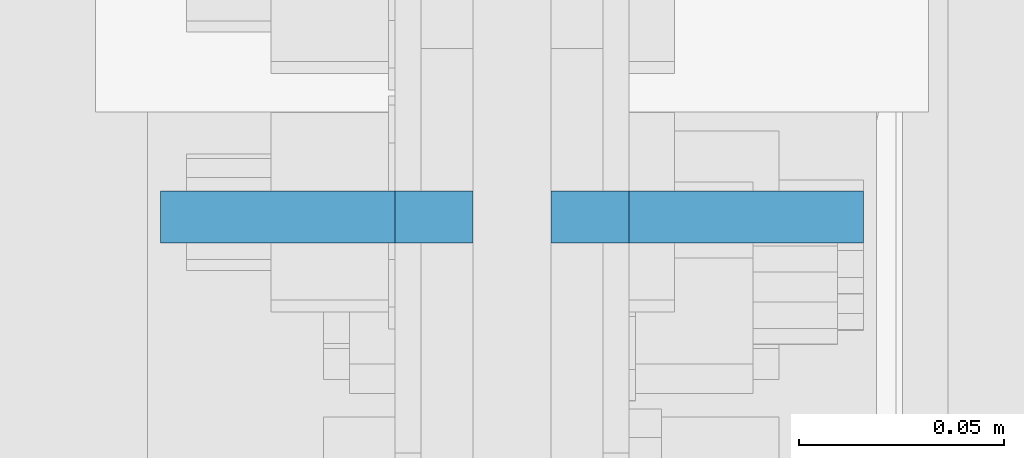
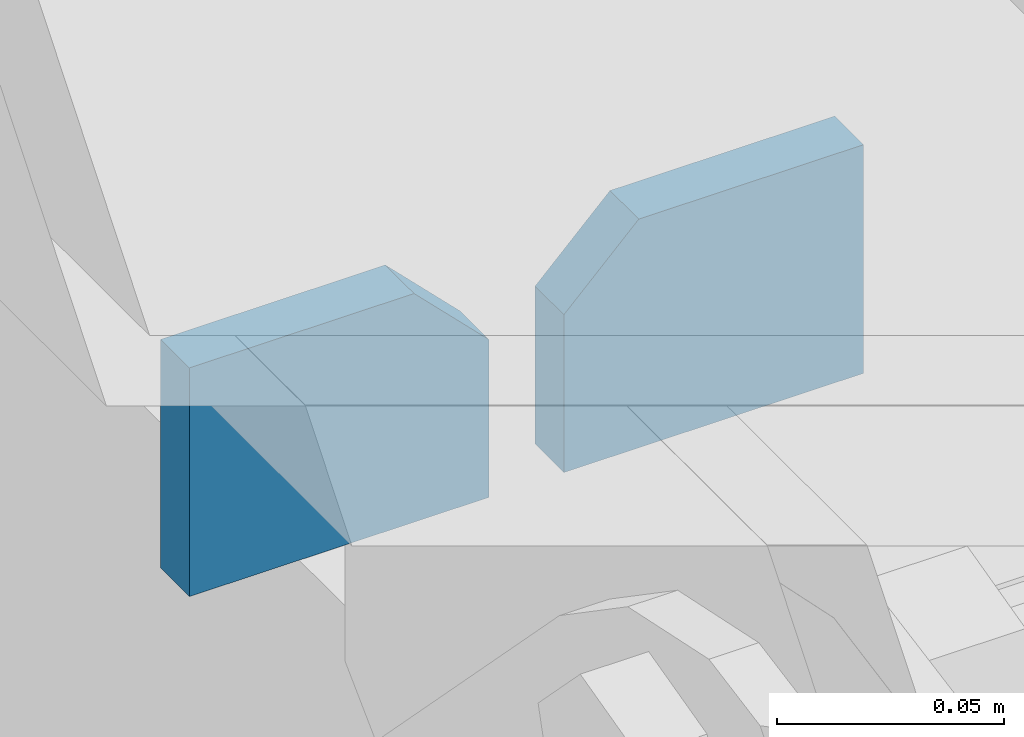
# One storey, part 1121 of 1179: 2 plates, 1 element without a shape of its own.
"""IFC2X3 building model written with IfcOpenShell, lengths in millimetres."""

from ifc_helpers import new_model, si_unit, frame, origin_with_axes, place, context, subcontext, project, spatial, faceted_brep, material, type_object, element, aggregate, save


model = new_model("IFC2X3")

# Units and contexts
model_context = context("Model", 3, precision=1e-05, world=origin_with_axes())
body_context = subcontext(model_context, "Body", "Model", "MODEL_VIEW")
ifc_project = project(units=[si_unit("LENGTHUNIT", "METRE", prefix="MILLI"), si_unit("AREAUNIT", "SQUARE_METRE"), si_unit("VOLUMEUNIT", "CUBIC_METRE"), si_unit("MASSUNIT", "GRAM", prefix="KILO"), si_unit("TIMEUNIT", "SECOND"), si_unit("PLANEANGLEUNIT", "RADIAN"), si_unit("SOLIDANGLEUNIT", "STERADIAN"), si_unit("THERMODYNAMICTEMPERATUREUNIT", "DEGREE_CELSIUS"), si_unit("LUMINOUSINTENSITYUNIT", "LUMEN")], contexts=[model_context])

# Site, building, storey
site_placement = place(None, origin_with_axes())
site = spatial("IfcSite", under=ifc_project, at=site_placement, CompositionType="ELEMENT")
building_placement = place(site_placement, origin_with_axes())
building = spatial("IfcBuilding", under=site, at=building_placement, Name="Undefined", CompositionType="ELEMENT")
storey_placement = place(building_placement, origin_with_axes())
storey = spatial("IfcBuildingStorey", under=building, at=storey_placement, Name="Undefined", CompositionType="ELEMENT", Elevation=0.0)

# Assembly, plates
assembly_placement = place(storey_placement, origin_with_axes())
assembly = element("IfcElementAssembly", 1, at=assembly_placement, inside=storey, Name="BEAM", AssemblyPlace="NOTDEFINED", PredefinedType="RIGID_FRAME")
ifc_material = material(Name="STEEL/A572-GR.50")
plate_type = type_object("IfcPlateType", PredefinedType="NOTDEFINED")
plate_1_placement = place(assembly_placement, frame((422.275000000003, 15773.4, 7683.5), z_axis=(-1.0, 0.0, 0.0), x_axis=(0.0, 0.0, -1.0)))
plate_1 = element("IfcPlate", 2, at=plate_1_placement, type_object=plate_type, material=ifc_material, Name="PLATE", context=body_context, shape_type="Brep", body=[
    faceted_brep([(0.0, 6.35000000000036, 19.0499999999993), (19.0500000000002, 6.35000000000036, 0.0), (19.0500000000002, -6.35000000000036, 0.0), (0.0, -6.35000000000036, 19.0499999999993), (0.0, -6.35000000000036, 76.2000000000044), (0.0, 6.35000000000036, 76.2000000000044), (61.493348936805, -6.35000000000036, 76.2000000000044), (61.493348936805, 6.35000000000036, 76.2000000000044), (61.493348936805, -6.35000000000036, 0.0), (61.493348936805, 6.35000000000036, 0.0)], [[[0, 1, 2, 3]], [[4, 5, 0, 3]], [[4, 6, 7, 5]], [[6, 8, 9, 7]], [[9, 8, 2, 1]], [[5, 7, 9, 1, 0]], [[8, 6, 4, 3, 2]]]),
])
plate_2_placement = place(assembly_placement, frame((441.325000000003, 15773.4, 7683.5), z_axis=(1.0, 0.0, 0.0), x_axis=(0.0, 0.0, -1.0)))
plate_2 = element("IfcPlate", 3, at=plate_2_placement, type_object=plate_type, material=ifc_material, Name="PLATE", context=body_context, shape_type="Brep", body=[
    faceted_brep([(0.0, 6.35000000000036, 19.0499999999993), (19.0500000000002, 6.35000000000036, 0.0), (19.0500000000002, -6.35000000000036, 0.0), (0.0, -6.35000000000036, 19.0499999999993), (0.0, -6.35000000000036, 76.2000000000044), (0.0, 6.35000000000036, 76.2000000000044), (61.493348936805, -6.35000000000036, 76.2000000000044), (61.493348936805, 6.35000000000036, 76.2000000000044), (61.493348936805, -6.35000000000036, 0.0), (61.493348936805, 6.35000000000036, 0.0)], [[[0, 1, 2, 3]], [[4, 5, 0, 3]], [[4, 6, 7, 5]], [[6, 8, 9, 7]], [[9, 8, 2, 1]], [[5, 7, 9, 1, 0]], [[8, 6, 4, 3, 2]]]),
])
aggregate(assembly, [plate_1, plate_2])

save(model, "model.ifc")
